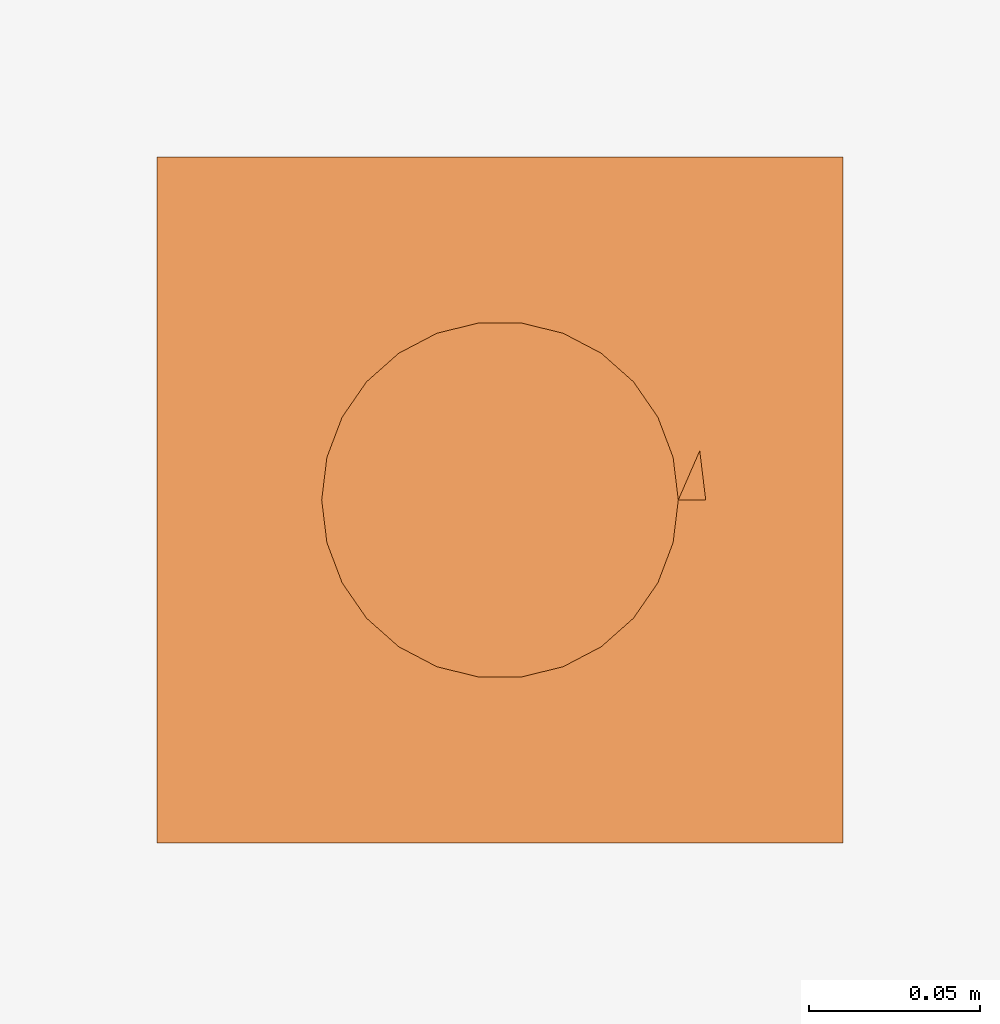
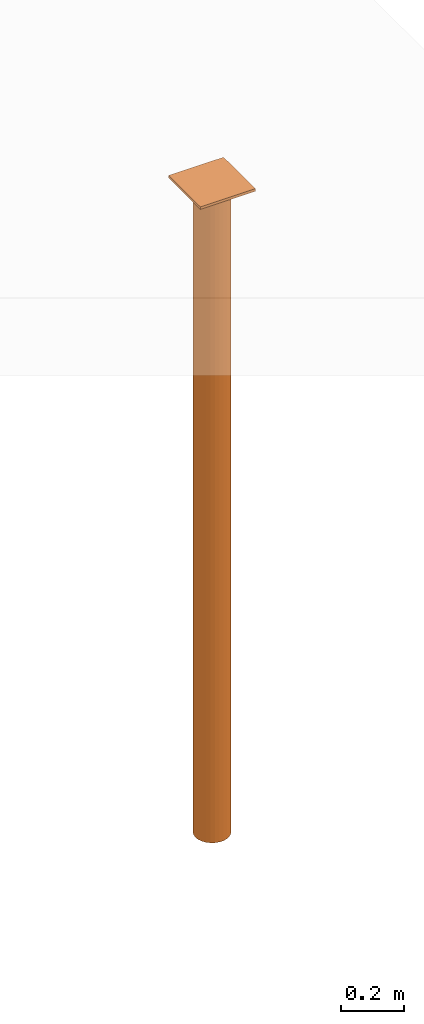
# Not in any storey, part 3 of 3: 2 proxies.
"""IFC4 model written with IfcOpenShell, lengths in metres."""

from ifc_helpers import new_model, entity, si_unit, converted_unit, direction, frame, origin_with_axes, place, context, project, polyline, circle_curve, parameter, trimmed, segment, composite_curve, outline, extrude, element, aggregate, save


model = new_model("IFC4")

# Units and contexts
model_context = context("Model", 3, precision=1e-05, world=origin_with_axes(), true_north=direction((0.0, 1.0, 0.0)))
ifc_project = project(units=[si_unit("LENGTHUNIT", "METRE"), si_unit("AREAUNIT", "SQUARE_METRE"), si_unit("VOLUMEUNIT", "CUBIC_METRE"), converted_unit("PLANEANGLEUNIT", "DEGREE", entity("IfcPlaneAngleMeasure", 0.017453292519943295), si_unit("PLANEANGLEUNIT", "RADIAN"), dimensions=[0, 0, 0, 0, 0, 0, 0])], contexts=[model_context])

# Proxies
placement = place(None, origin_with_axes())
proxy_1 = element("IfcBuildingElementProxy", 1, at=placement, Name="Structure002", context=model_context, shape_type="SweptSolid", body=[
    extrude(outline(polyline([(-0.1, -0.1), (0.1, -0.1), (0.1, 0.1), (-0.1, 0.1), (-0.1, -0.1)])), frame((5.0, 0.0, 2.49), z_axis=(0.0, 0.0, 1.0), x_axis=(1.0, 0.0, 0.0)), (0.0, 0.0, 1.0), 0.01),
])
proxy_2 = element("IfcBuildingElementProxy", 2, at=placement, Name="Structure001", PredefinedType="ELEMENT", context=model_context, shape_type="SweptSolid", body=[
    extrude(outline(composite_curve([segment(trimmed(circle_curve(frame((-4.10641831649645e-12, -9.06681104277053e-18, 0.0), z_axis=(0.0, 0.0, 1.0), x_axis=(1.0, 0.0, 0.0)), 0.052), [parameter(0.0)], [parameter(0.0)], True, "PARAMETER"), True, "CONTINUOUS"), segment(polyline([(0.0519999999958936, -9.06681104276977e-18, 0.0), (0.0599999999958936, -9.06681104276977e-18, 0.0)]), True, "CONTINUOUS"), segment(trimmed(circle_curve(frame((-4.10641831649645e-12, -9.06681104277053e-18, 0.0), z_axis=(0.0, 0.0, 1.0), x_axis=(1.0, 0.0, 0.0)), 0.06), [parameter(0.0)], [parameter(0.0)], True, "PARAMETER"), True, "CONTINUOUS")], self_intersect=False)), frame((5.00000000000411, 9.06681104276977e-18, 0.0), z_axis=(0.0, 0.0, 1.0), x_axis=(1.0, 0.0, 0.0)), (0.0, 0.0, 1.0), 2.49),
])
aggregate(proxy_1, [proxy_2])

save(model, "model.ifc")
